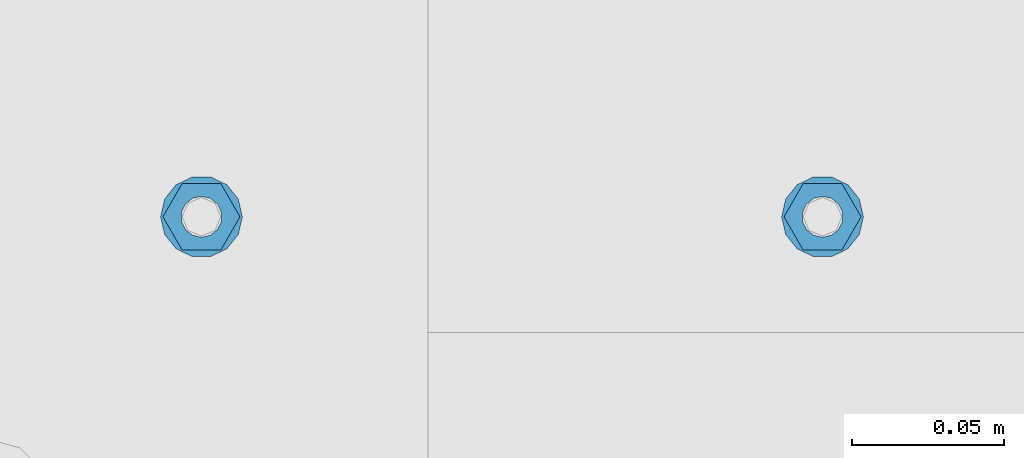
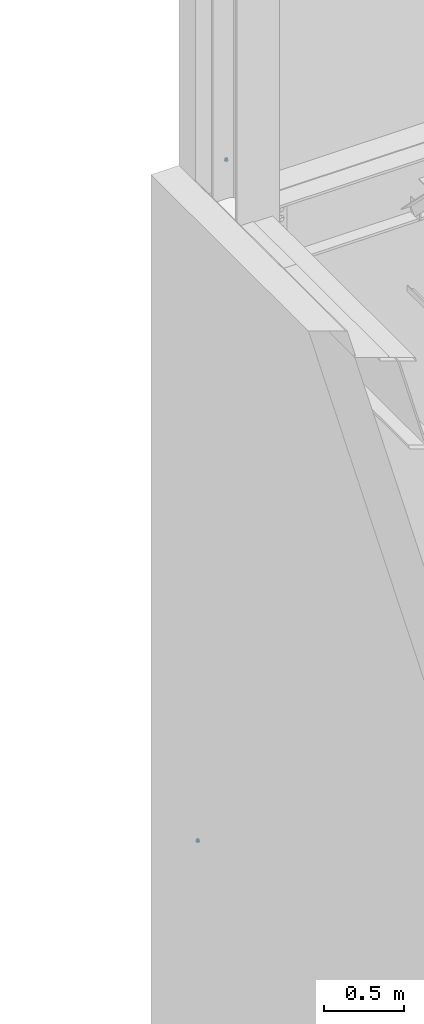
# One storey, part 648 of 1179: 4 columns, 2 elements without a shape of their own.
"""IFC2X3 building model written with IfcOpenShell, lengths in millimetres."""

from ifc_helpers import new_model, si_unit, frame, origin_with_axes, place, context, subcontext, project, spatial, faceted_brep, material, type_object, element, aggregate, save


model = new_model("IFC2X3")

# Units and contexts
model_context = context("Model", 3, precision=1e-05, world=origin_with_axes())
body_context = subcontext(model_context, "Body", "Model", "MODEL_VIEW")
ifc_project = project(units=[si_unit("LENGTHUNIT", "METRE", prefix="MILLI"), si_unit("AREAUNIT", "SQUARE_METRE"), si_unit("VOLUMEUNIT", "CUBIC_METRE"), si_unit("MASSUNIT", "GRAM", prefix="KILO"), si_unit("TIMEUNIT", "SECOND"), si_unit("PLANEANGLEUNIT", "RADIAN"), si_unit("SOLIDANGLEUNIT", "STERADIAN"), si_unit("THERMODYNAMICTEMPERATUREUNIT", "DEGREE_CELSIUS"), si_unit("LUMINOUSINTENSITYUNIT", "LUMEN")], contexts=[model_context])

# Site, building, storey
site_placement = place(None, origin_with_axes())
site = spatial("IfcSite", under=ifc_project, at=site_placement, CompositionType="ELEMENT")
building_placement = place(site_placement, origin_with_axes())
building = spatial("IfcBuilding", under=site, at=building_placement, Name="Undefined", CompositionType="ELEMENT")
storey_placement = place(building_placement, origin_with_axes())
storey = spatial("IfcBuildingStorey", under=building, at=storey_placement, Name="Undefined", CompositionType="ELEMENT", Elevation=0.0)

# Assembly, column
assembly_1_placement = place(storey_placement, origin_with_axes())
assembly_1 = element("IfcElementAssembly", 1, at=assembly_1_placement, inside=storey, Name="BEAM", AssemblyPlace="NOTDEFINED", PredefinedType="RIGID_FRAME")
ifc_material = material(Name="STEEL/A307")
column_type_1 = type_object("IfcColumnType", Name="1/2_WASHER", PredefinedType="NOTDEFINED")
column_1_placement = place(assembly_1_placement, frame((482.599999999999, 41529.0, 13252.45), z_axis=(0.0, 1.0, 0.0), x_axis=(0.0, 0.0, 1.0)))
column_1 = element("IfcColumn", 2, at=column_1_placement, type_object=column_type_1, material=ifc_material, Name="WASHER", ObjectType="1/2_WASHER", context=body_context, shape_type="Brep", body=[
    faceted_brep([(0.0, -13.4899997711182, 0.0), (0.0, -12.1540698217868, -5.85309154138758), (4.76249999999891, -12.1540698217868, -5.85309154138758), (4.76249999999891, -13.4899997711182, 0.0), (0.0, -8.41087728436833, -10.5469065195466), (4.76249999999891, -8.41087728436833, -10.5469065195466), (0.0, -3.00180734814057, -13.1517773121896), (4.76249999999891, -3.00180734814057, -13.1517773121896), (0.0, 3.00180734814057, -13.1517773121896), (4.76249999999891, 3.00180734814057, -13.1517773121896), (0.0, 8.41087728436833, -10.5469065195466), (4.76249999999891, 8.41087728436833, -10.5469065195466), (0.0, 12.1540698217868, -5.85309154138758), (4.76249999999891, 12.1540698217868, -5.85309154138758), (0.0, 13.4899997711182, 0.0), (4.76249999999891, 13.4899997711182, 0.0), (0.0, 12.1540698217868, 5.85309154138758), (4.76249999999891, 12.1540698217868, 5.85309154138758), (0.0, 8.41087728436833, 10.5469065195466), (4.76249999999891, 8.41087728436833, 10.5469065195466), (0.0, 3.00180734814057, 13.1517773121896), (4.76249999999891, 3.00180734814057, 13.1517773121896), (0.0, -3.00180734814057, 13.1517773121896), (4.76249999999891, -3.00180734814057, 13.1517773121896), (0.0, -8.41087728436833, 10.5469065195466), (4.76249999999891, -8.41087728436833, 10.5469065195466), (0.0, -12.1540698217868, 5.85309154138758), (4.76249999999891, -12.1540698217868, 5.85309154138758), (0.0, 0.0, 6.75), (0.0, 2.9287152390425, 6.08153985834178), (4.76249999999891, 2.9287152390425, 6.08153985834178), (4.76249999999891, 0.0, 6.75), (0.0, 5.27736250665839, 4.2085561625463), (4.76249999999891, 5.27736250665839, 4.2085561625463), (0.0, 6.58076340722619, 1.50201630420543), (4.76249999999891, 6.58076340722619, 1.50201630420543), (0.0, 6.58076340722619, -1.50201630420543), (4.76249999999891, 6.58076340722619, -1.50201630420543), (0.0, 5.27736250665839, -4.2085561625463), (4.76249999999891, 5.27736250665839, -4.2085561625463), (0.0, 2.9287152390425, -6.08153985834088), (4.76249999999891, 2.9287152390425, -6.08153985834088), (0.0, 0.0, -6.75), (4.76249999999891, 0.0, -6.75), (0.0, -2.9287152390425, -6.08153985834178), (4.76249999999891, -2.9287152390425, -6.08153985834178), (0.0, -5.27736250665839, -4.2085561625463), (4.76249999999891, -5.27736250665839, -4.2085561625463), (0.0, -6.58076340722619, -1.50201630420543), (4.76249999999891, -6.58076340722619, -1.50201630420543), (0.0, -6.58076340722619, 1.50201630420543), (4.76249999999891, -6.58076340722619, 1.50201630420543), (0.0, -5.27736250665839, 4.2085561625463), (4.76249999999891, -5.27736250665839, 4.2085561625463), (0.0, -2.9287152390425, 6.08153985834088), (4.76249999999891, -2.9287152390425, 6.08153985834088)], [[[0, 1, 2, 3]], [[1, 4, 5, 2]], [[4, 6, 7, 5]], [[6, 8, 9, 7]], [[8, 10, 11, 9]], [[10, 12, 13, 11]], [[12, 14, 15, 13]], [[14, 16, 17, 15]], [[16, 18, 19, 17]], [[18, 20, 21, 19]], [[20, 22, 23, 21]], [[22, 24, 25, 23]], [[24, 26, 27, 25]], [[26, 0, 3, 27]], [[28, 29, 30, 31]], [[29, 32, 33, 30]], [[32, 34, 35, 33]], [[34, 36, 37, 35]], [[36, 38, 39, 37]], [[38, 40, 41, 39]], [[40, 42, 43, 41]], [[42, 44, 45, 43]], [[44, 46, 47, 45]], [[46, 48, 49, 47]], [[48, 50, 51, 49]], [[50, 52, 53, 51]], [[52, 54, 55, 53]], [[54, 28, 31, 55]], [[5, 7, 9, 11, 13, 15, 17, 19, 21, 23, 25, 27, 3, 2], [33, 35, 37, 39, 41, 43, 45, 47, 49, 51, 53, 55, 31, 30]], [[26, 24, 22, 20, 18, 16, 14, 12, 10, 8, 6, 4, 1, 0], [54, 52, 50, 48, 46, 44, 42, 40, 38, 36, 34, 32, 29, 28]]]),
])

assembly_2_placement = place(storey_placement, origin_with_axes())
assembly_2 = element("IfcElementAssembly", 3, at=assembly_2_placement, inside=storey, Name="BEAM", AssemblyPlace="NOTDEFINED", PredefinedType="RIGID_FRAME")
column_2_placement = place(assembly_2_placement, frame((277.812523065457, 41529.0, 8147.05), z_axis=(0.0, 1.0, 0.0), x_axis=(0.0, 0.0, 1.0)))
column_2 = element("IfcColumn", 4, at=column_2_placement, type_object=column_type_1, material=ifc_material, Name="WASHER", ObjectType="1/2_WASHER", context=body_context, shape_type="Brep", body=[
    faceted_brep([(0.0, -13.4899997711182, 0.0), (0.0, -12.1540698217868, -5.85309154138758), (4.76249999999891, -12.1540698217868, -5.85309154138758), (4.76249999999891, -13.4899997711182, 0.0), (0.0, -8.41087728436833, -10.5469065195466), (4.76249999999891, -8.41087728436833, -10.5469065195466), (0.0, -3.00180734814057, -13.1517773121896), (4.76249999999891, -3.00180734814057, -13.1517773121896), (0.0, 3.00180734814057, -13.1517773121896), (4.76249999999891, 3.00180734814057, -13.1517773121896), (0.0, 8.41087728436833, -10.5469065195466), (4.76249999999891, 8.41087728436833, -10.5469065195466), (0.0, 12.1540698217868, -5.85309154138758), (4.76249999999891, 12.1540698217868, -5.85309154138758), (0.0, 13.4899997711182, 0.0), (4.76249999999891, 13.4899997711182, 0.0), (0.0, 12.1540698217868, 5.85309154138758), (4.76249999999891, 12.1540698217868, 5.85309154138758), (0.0, 8.41087728436833, 10.5469065195466), (4.76249999999891, 8.41087728436833, 10.5469065195466), (0.0, 3.00180734814057, 13.1517773121896), (4.76249999999891, 3.00180734814057, 13.1517773121896), (0.0, -3.00180734814057, 13.1517773121896), (4.76249999999891, -3.00180734814057, 13.1517773121896), (0.0, -8.41087728436833, 10.5469065195466), (4.76249999999891, -8.41087728436833, 10.5469065195466), (0.0, -12.1540698217868, 5.85309154138758), (4.76249999999891, -12.1540698217868, 5.85309154138758), (0.0, 0.0, 6.75), (0.0, 2.9287152390425, 6.08153985834178), (4.76249999999891, 2.9287152390425, 6.08153985834178), (4.76249999999891, 0.0, 6.75), (0.0, 5.27736250665839, 4.2085561625463), (4.76249999999891, 5.27736250665839, 4.2085561625463), (0.0, 6.58076340722619, 1.50201630420543), (4.76249999999891, 6.58076340722619, 1.50201630420543), (0.0, 6.58076340722619, -1.50201630420543), (4.76249999999891, 6.58076340722619, -1.50201630420543), (0.0, 5.27736250665839, -4.2085561625463), (4.76249999999891, 5.27736250665839, -4.2085561625463), (0.0, 2.9287152390425, -6.08153985834088), (4.76249999999891, 2.9287152390425, -6.08153985834088), (0.0, 0.0, -6.75), (4.76249999999891, 0.0, -6.75), (0.0, -2.9287152390425, -6.08153985834178), (4.76249999999891, -2.9287152390425, -6.08153985834178), (0.0, -5.27736250665839, -4.2085561625463), (4.76249999999891, -5.27736250665839, -4.2085561625463), (0.0, -6.58076340722619, -1.50201630420543), (4.76249999999891, -6.58076340722619, -1.50201630420543), (0.0, -6.58076340722619, 1.50201630420543), (4.76249999999891, -6.58076340722619, 1.50201630420543), (0.0, -5.27736250665839, 4.2085561625463), (4.76249999999891, -5.27736250665839, 4.2085561625463), (0.0, -2.9287152390425, 6.08153985834088), (4.76249999999891, -2.9287152390425, 6.08153985834088)], [[[0, 1, 2, 3]], [[1, 4, 5, 2]], [[4, 6, 7, 5]], [[6, 8, 9, 7]], [[8, 10, 11, 9]], [[10, 12, 13, 11]], [[12, 14, 15, 13]], [[14, 16, 17, 15]], [[16, 18, 19, 17]], [[18, 20, 21, 19]], [[20, 22, 23, 21]], [[22, 24, 25, 23]], [[24, 26, 27, 25]], [[26, 0, 3, 27]], [[28, 29, 30, 31]], [[29, 32, 33, 30]], [[32, 34, 35, 33]], [[34, 36, 37, 35]], [[36, 38, 39, 37]], [[38, 40, 41, 39]], [[40, 42, 43, 41]], [[42, 44, 45, 43]], [[44, 46, 47, 45]], [[46, 48, 49, 47]], [[48, 50, 51, 49]], [[50, 52, 53, 51]], [[52, 54, 55, 53]], [[54, 28, 31, 55]], [[5, 7, 9, 11, 13, 15, 17, 19, 21, 23, 25, 27, 3, 2], [33, 35, 37, 39, 41, 43, 45, 47, 49, 51, 53, 55, 31, 30]], [[26, 24, 22, 20, 18, 16, 14, 12, 10, 8, 6, 4, 1, 0], [54, 52, 50, 48, 46, 44, 42, 40, 38, 36, 34, 32, 29, 28]]]),
])

# Column
column_type_2 = type_object("IfcColumnType", Name="1/2_HEAVY_HEX_NUT", PredefinedType="NOTDEFINED")
column_3_placement = place(assembly_1_placement, frame((482.599999999999, 41529.0, 13257.2125), z_axis=(0.0, 1.0, 0.0), x_axis=(0.0, 0.0, 1.0)))
column_3 = element("IfcColumn", 5, at=column_3_placement, type_object=column_type_2, material=ifc_material, Name="NUT", ObjectType="1/2_HEAVY_HEX_NUT", context=body_context, shape_type="Brep", body=[
    faceted_brep([(0.0, -12.7, 0.0), (0.0, -6.34999990463257, -11.0), (12.7000000000007, -6.34999990463257, -11.0), (12.7000000000007, -12.6999998092651, 0.0), (0.0, 6.34999990463257, -11.0), (12.7000000000007, 6.34999990463257, -11.0), (0.0, 12.7, 0.0), (12.7000000000007, 12.6999998092651, 0.0), (0.0, 6.34999990463257, 11.0), (12.7000000000007, 6.34999990463257, 11.0), (0.0, -6.34999990463257, 11.0), (12.7000000000007, -6.34999990463257, 11.0), (0.0, 0.0, 6.75), (0.0, 2.9287152390425, 6.08153985834178), (12.7000000000007, 2.9287152390425, 6.08153985834178), (12.7000000000007, 0.0, 6.75), (0.0, 5.27736250665839, 4.2085561625463), (12.7000000000007, 5.27736250665839, 4.2085561625463), (0.0, 6.58076340722619, 1.50201630420543), (12.7000000000007, 6.58076340722619, 1.50201630420543), (0.0, 6.58076340722619, -1.50201630420543), (12.7000000000007, 6.58076340722619, -1.50201630420543), (0.0, 5.27736250665839, -4.2085561625463), (12.7000000000007, 5.27736250665839, -4.2085561625463), (0.0, 2.9287152390425, -6.08153985834088), (12.7000000000007, 2.9287152390425, -6.08153985834088), (0.0, 0.0, -6.75), (12.7000000000007, 0.0, -6.75), (0.0, -2.9287152390425, -6.08153985834178), (12.7000000000007, -2.9287152390425, -6.08153985834178), (0.0, -5.27736250665839, -4.2085561625463), (12.7000000000007, -5.27736250665839, -4.2085561625463), (0.0, -6.58076340722619, -1.50201630420543), (12.7000000000007, -6.58076340722619, -1.50201630420543), (0.0, -6.58076340722619, 1.50201630420543), (12.7000000000007, -6.58076340722619, 1.50201630420543), (0.0, -5.27736250665839, 4.2085561625463), (12.7000000000007, -5.27736250665839, 4.2085561625463), (0.0, -2.9287152390425, 6.08153985834088), (12.7000000000007, -2.9287152390425, 6.08153985834088)], [[[0, 1, 2, 3]], [[1, 4, 5, 2]], [[4, 6, 7, 5]], [[6, 8, 9, 7]], [[8, 10, 11, 9]], [[10, 0, 3, 11]], [[12, 13, 14, 15]], [[13, 16, 17, 14]], [[16, 18, 19, 17]], [[18, 20, 21, 19]], [[20, 22, 23, 21]], [[22, 24, 25, 23]], [[24, 26, 27, 25]], [[26, 28, 29, 27]], [[28, 30, 31, 29]], [[30, 32, 33, 31]], [[32, 34, 35, 33]], [[34, 36, 37, 35]], [[36, 38, 39, 37]], [[38, 12, 15, 39]], [[5, 7, 9, 11, 3, 2], [17, 19, 21, 23, 25, 27, 29, 31, 33, 35, 37, 39, 15, 14]], [[10, 8, 6, 4, 1, 0], [38, 36, 34, 32, 30, 28, 26, 24, 22, 20, 18, 16, 13, 12]]]),
])

aggregate(assembly_1, [column_1, column_3])

column_4_placement = place(assembly_2_placement, frame((277.812523065457, 41529.0, 8151.8125), z_axis=(0.0, 1.0, 0.0), x_axis=(0.0, 0.0, 1.0)))
column_4 = element("IfcColumn", 6, at=column_4_placement, type_object=column_type_2, material=ifc_material, Name="NUT", ObjectType="1/2_HEAVY_HEX_NUT", context=body_context, shape_type="Brep", body=[
    faceted_brep([(0.0, -12.7, 0.0), (0.0, -6.34999990463257, -11.0), (12.7000000000007, -6.34999990463257, -11.0), (12.7000000000007, -12.6999998092651, 0.0), (0.0, 6.34999990463257, -11.0), (12.7000000000007, 6.34999990463257, -11.0), (0.0, 12.7, 0.0), (12.7000000000007, 12.6999998092651, 0.0), (0.0, 6.34999990463257, 11.0), (12.7000000000007, 6.34999990463257, 11.0), (0.0, -6.34999990463257, 11.0), (12.7000000000007, -6.34999990463257, 11.0), (0.0, 0.0, 6.75), (0.0, 2.9287152390425, 6.08153985834178), (12.7000000000007, 2.9287152390425, 6.08153985834178), (12.7000000000007, 0.0, 6.75), (0.0, 5.27736250665839, 4.2085561625463), (12.7000000000007, 5.27736250665839, 4.2085561625463), (0.0, 6.58076340722619, 1.50201630420543), (12.7000000000007, 6.58076340722619, 1.50201630420543), (0.0, 6.58076340722619, -1.50201630420543), (12.7000000000007, 6.58076340722619, -1.50201630420543), (0.0, 5.27736250665839, -4.2085561625463), (12.7000000000007, 5.27736250665839, -4.2085561625463), (0.0, 2.9287152390425, -6.08153985834088), (12.7000000000007, 2.9287152390425, -6.08153985834088), (0.0, 0.0, -6.75), (12.7000000000007, 0.0, -6.75), (0.0, -2.9287152390425, -6.08153985834178), (12.7000000000007, -2.9287152390425, -6.08153985834178), (0.0, -5.27736250665839, -4.2085561625463), (12.7000000000007, -5.27736250665839, -4.2085561625463), (0.0, -6.58076340722619, -1.50201630420543), (12.7000000000007, -6.58076340722619, -1.50201630420543), (0.0, -6.58076340722619, 1.50201630420543), (12.7000000000007, -6.58076340722619, 1.50201630420543), (0.0, -5.27736250665839, 4.2085561625463), (12.7000000000007, -5.27736250665839, 4.2085561625463), (0.0, -2.9287152390425, 6.08153985834088), (12.7000000000007, -2.9287152390425, 6.08153985834088)], [[[0, 1, 2, 3]], [[1, 4, 5, 2]], [[4, 6, 7, 5]], [[6, 8, 9, 7]], [[8, 10, 11, 9]], [[10, 0, 3, 11]], [[12, 13, 14, 15]], [[13, 16, 17, 14]], [[16, 18, 19, 17]], [[18, 20, 21, 19]], [[20, 22, 23, 21]], [[22, 24, 25, 23]], [[24, 26, 27, 25]], [[26, 28, 29, 27]], [[28, 30, 31, 29]], [[30, 32, 33, 31]], [[32, 34, 35, 33]], [[34, 36, 37, 35]], [[36, 38, 39, 37]], [[38, 12, 15, 39]], [[5, 7, 9, 11, 3, 2], [17, 19, 21, 23, 25, 27, 29, 31, 33, 35, 37, 39, 15, 14]], [[10, 8, 6, 4, 1, 0], [38, 36, 34, 32, 30, 28, 26, 24, 22, 20, 18, 16, 13, 12]]]),
])

aggregate(assembly_2, [column_2, column_4])

save(model, "model.ifc")
